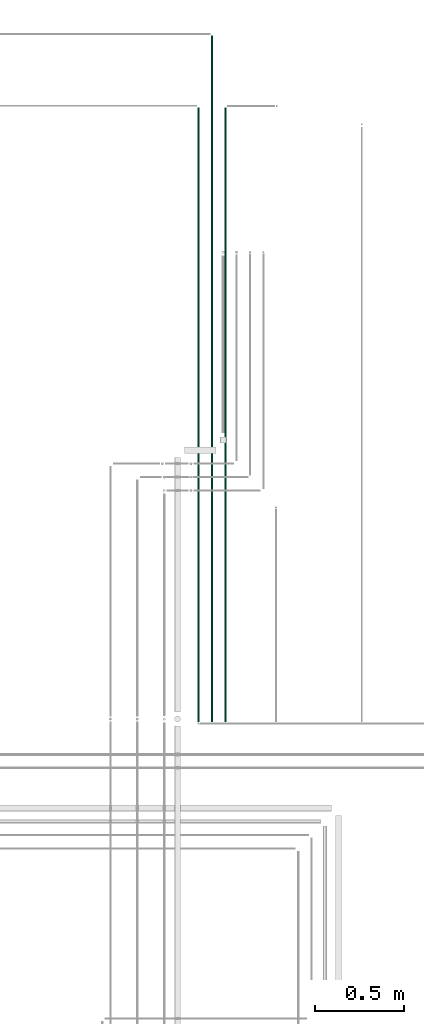
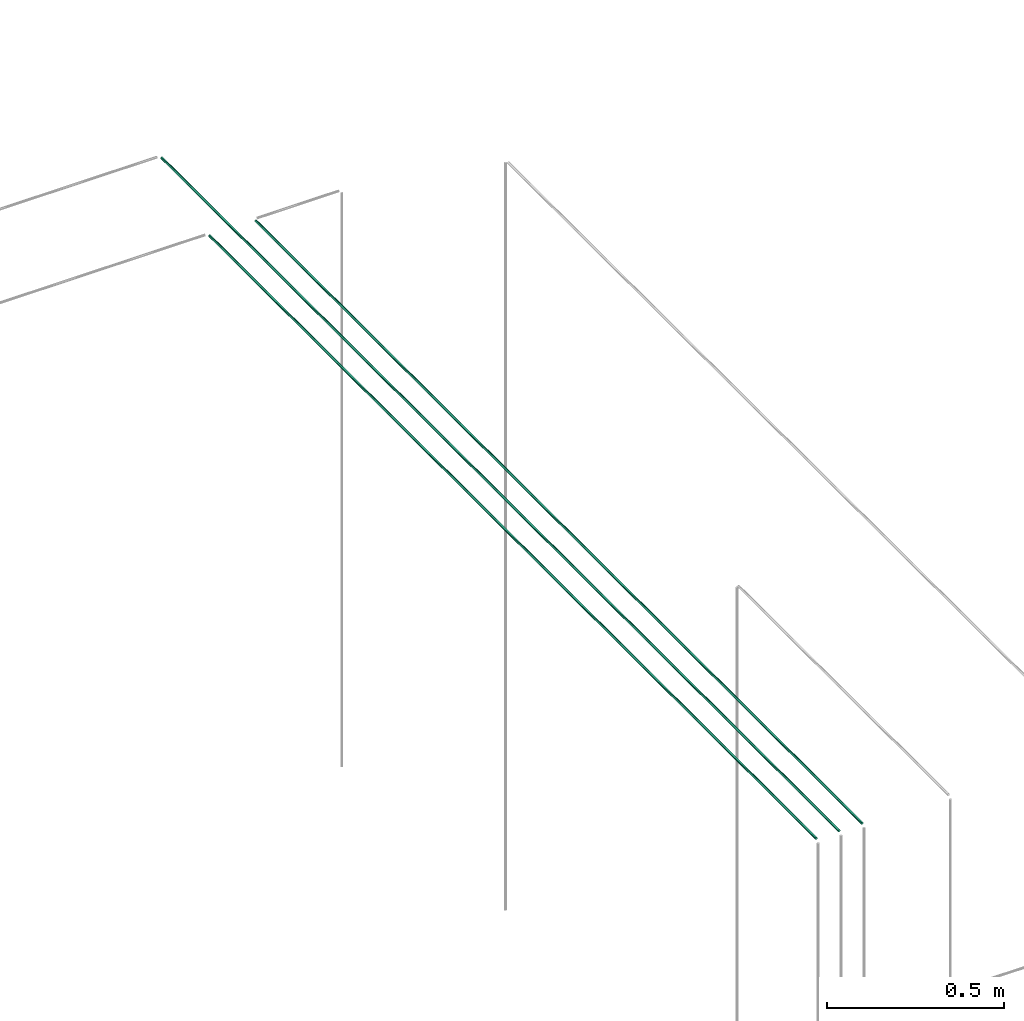
# One storey, part 112 of 331: 3 flow segments.
"""IFC2X3 building model written with IfcOpenShell, lengths in millimetres."""

from ifc_helpers import new_model, entity, si_unit, converted_unit, derived_unit, direction, frame, frame_2d, origin, origin_2d_with_axis, place, context, subcontext, project, spatial, circle, extrude, type_object, element, save


model = new_model("IFC2X3")

# Units and contexts
model_context = context("Model", 3, precision=0.01, world=origin(), true_north=direction((6.12303176911189e-17, 1.0)))
body_context = subcontext(model_context, "Body", "Model", "MODEL_VIEW")
ifc_project = project(units=[si_unit("LENGTHUNIT", "METRE", prefix="MILLI"), si_unit("AREAUNIT", "SQUARE_METRE"), si_unit("VOLUMEUNIT", "CUBIC_METRE"), converted_unit("PLANEANGLEUNIT", "DEGREE", entity("IfcRatioMeasure", 0.0174532925199433), si_unit("PLANEANGLEUNIT", "RADIAN"), dimensions=[0, 0, 0, 0, 0, 0, 0]), si_unit("MASSUNIT", "GRAM", prefix="KILO"), derived_unit("MASSDENSITYUNIT", [(si_unit("MASSUNIT", "GRAM", prefix="KILO"), 1), (si_unit("LENGTHUNIT", "METRE"), -3)]), derived_unit("MOMENTOFINERTIAUNIT", [(si_unit("LENGTHUNIT", "METRE"), 4)]), si_unit("TIMEUNIT", "SECOND"), si_unit("FREQUENCYUNIT", "HERTZ"), si_unit("THERMODYNAMICTEMPERATUREUNIT", "DEGREE_CELSIUS"), derived_unit("THERMALTRANSMITTANCEUNIT", [(si_unit("MASSUNIT", "GRAM", prefix="KILO"), 1), (si_unit("THERMODYNAMICTEMPERATUREUNIT", "KELVIN"), -1), (si_unit("TIMEUNIT", "SECOND"), -3)]), derived_unit("VOLUMETRICFLOWRATEUNIT", [(si_unit("LENGTHUNIT", "METRE"), 3), (si_unit("TIMEUNIT", "SECOND"), -1)]), derived_unit("MASSFLOWRATEUNIT", [(si_unit("MASSUNIT", "GRAM", prefix="KILO"), 1), (si_unit("TIMEUNIT", "SECOND"), -1)]), derived_unit("ROTATIONALFREQUENCYUNIT", [(si_unit("TIMEUNIT", "SECOND"), -1)]), si_unit("ELECTRICCURRENTUNIT", "AMPERE"), si_unit("ELECTRICVOLTAGEUNIT", "VOLT"), si_unit("POWERUNIT", "WATT"), si_unit("FORCEUNIT", "NEWTON", prefix="KILO"), si_unit("ILLUMINANCEUNIT", "LUX"), si_unit("LUMINOUSFLUXUNIT", "LUMEN"), si_unit("LUMINOUSINTENSITYUNIT", "CANDELA"), derived_unit("USERDEFINED", [(si_unit("MASSUNIT", "GRAM", prefix="KILO"), -1), (si_unit("LENGTHUNIT", "METRE"), -2), (si_unit("TIMEUNIT", "SECOND"), 3), (si_unit("LUMINOUSFLUXUNIT", "LUMEN"), 1)]), derived_unit("LINEARVELOCITYUNIT", [(si_unit("LENGTHUNIT", "METRE"), 1), (si_unit("TIMEUNIT", "SECOND"), -1)]), si_unit("PRESSUREUNIT", "PASCAL"), derived_unit("USERDEFINED", [(si_unit("LENGTHUNIT", "METRE"), -2), (si_unit("MASSUNIT", "GRAM", prefix="KILO"), 1), (si_unit("TIMEUNIT", "SECOND"), -2)]), derived_unit("LINEARFORCEUNIT", [(si_unit("MASSUNIT", "GRAM", prefix="KILO"), 1), (si_unit("LENGTHUNIT", "METRE"), 1), (si_unit("TIMEUNIT", "SECOND"), -2), (si_unit("LENGTHUNIT", "METRE"), -1)]), derived_unit("PLANARFORCEUNIT", [(si_unit("MASSUNIT", "GRAM", prefix="KILO"), 1), (si_unit("LENGTHUNIT", "METRE"), 1), (si_unit("TIMEUNIT", "SECOND"), -2), (si_unit("LENGTHUNIT", "METRE"), -2)])], contexts=[model_context])

# Site, building, storey
site_placement = place(None, frame((0.0, -0.00077364408347762, 0.0)))
site = spatial("IfcSite", under=ifc_project, at=site_placement, CompositionType="ELEMENT")
building_placement = place(site_placement, origin())
building = spatial("IfcBuilding", under=site, at=building_placement, CompositionType="ELEMENT")
storey_placement = place(building_placement, origin())
storey = spatial("IfcBuildingStorey", under=building, at=storey_placement, CompositionType="ELEMENT", Elevation=0.0)

# Flow segments
pipe_segment_type = type_object("IfcPipeSegmentType", PredefinedType="NOTDEFINED")
flow_segment_1_placement = place(storey_placement, frame((59952.5518978448, 16308.5068408728, 7344.40472776407)))
element("IfcFlowSegment", 1, at=flow_segment_1_placement, inside=storey, type_object=pipe_segment_type, context=body_context, shape_type="SweptSolid", body=[
    extrude(circle(Radius=4.0, at=frame_2d((-8.66293703438714e-12, 0.0), x_axis=(1.0, 0.0))), frame((5.59527223591499, 0.0, 5.59527223591607), z_axis=(0.0, 1.0, 0.0), x_axis=(-1.0, 0.0, 0.0)), (0.0, 0.0, 1.0), 3831.49360468392),
])
flow_segment_2_placement = place(storey_placement, frame((59877.8372954879, 16308.5068408728, 7344.40472776407)))
element("IfcFlowSegment", 2, at=flow_segment_2_placement, inside=storey, type_object=pipe_segment_type, context=body_context, shape_type="SweptSolid", body=[
    extrude(circle(Radius=4.0, at=frame_2d((-8.66293703438714e-12, 0.0), x_axis=(1.0, 0.0))), frame((5.59527223591499, 0.0, 5.59527223591607), z_axis=(0.0, 1.0, 0.0), x_axis=(-1.0, 0.0, 0.0)), (0.0, 0.0, 1.0), 3431.49393277142),
])
flow_segment_3_placement = place(building_placement, frame((60027.5518978448, 16308.5068408728, 7344.4047277641)))
element("IfcFlowSegment", 3, at=flow_segment_3_placement, inside=storey, type_object=pipe_segment_type, context=body_context, shape_type="SweptSolid", body=[
    extrude(circle(Radius=4.0, at=origin_2d_with_axis()), frame((5.59527223591499, 0.0, 5.59527223591607), z_axis=(0.0, 1.0, 0.0), x_axis=(1.0, 0.0, 0.0)), (0.0, 0.0, 1.0), 3430.00000000001),
])

save(model, "model.ifc")
